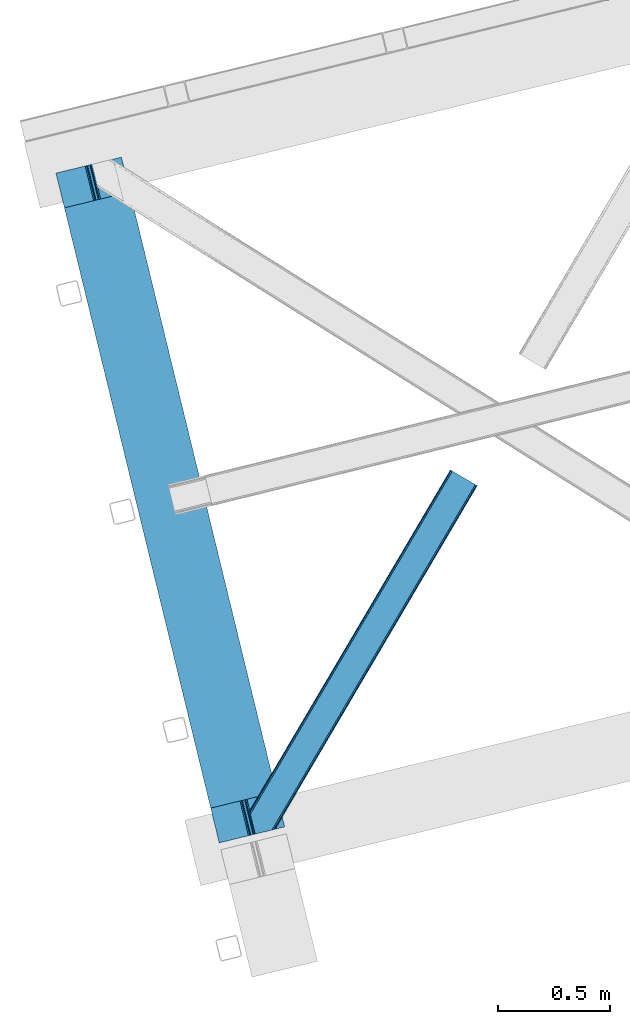
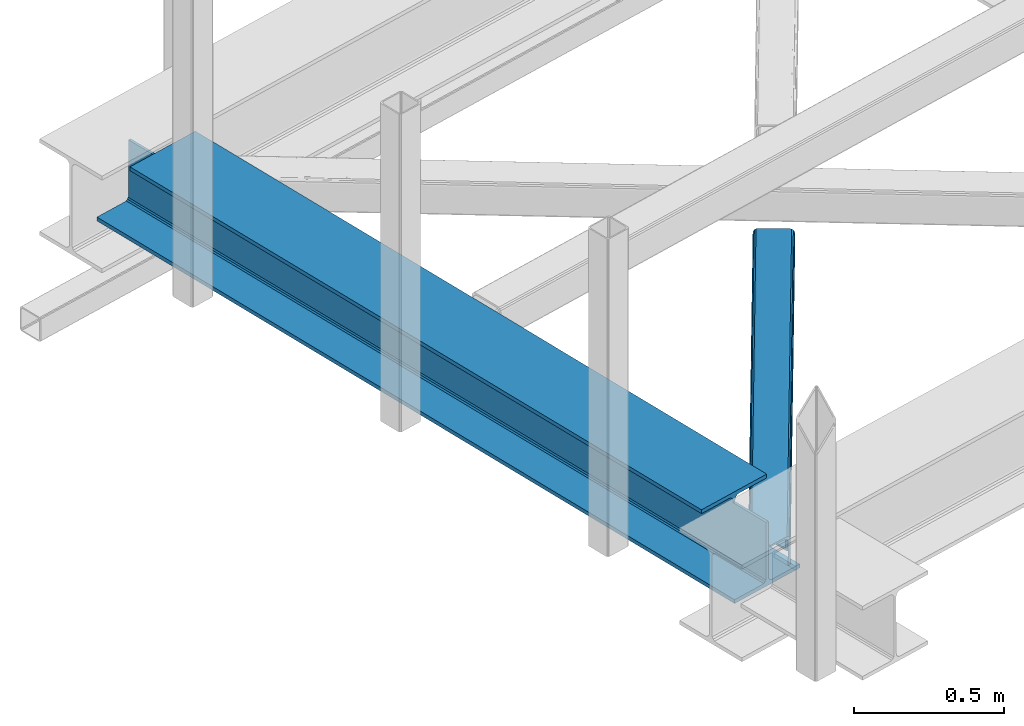
# One storey, part 17 of 67: 1 beam, 1 member.
"""IFC4 building model written with IfcOpenShell, lengths in millimetres."""

from ifc_helpers import new_model, entity, si_unit, converted_unit, derived_unit, direction, frame, origin, place, context, subcontext, project, spatial, triangles, polygons, material, type_object, element, save


model = new_model("IFC4")

# Units and contexts
model_context = context("Model", 3, precision=0.01, world=origin(), true_north=direction((6.12303176911189e-17, 1.0)))
plan_context = context("Plan", 3, precision=0.01, world=origin(), true_north=direction((6.12303176911189e-17, 1.0)))
body_context = subcontext(model_context, "Body", "Model", "MODEL_VIEW")
ifc_project = project(units=[si_unit("LENGTHUNIT", "METRE", prefix="MILLI"), si_unit("AREAUNIT", "SQUARE_METRE"), si_unit("VOLUMEUNIT", "CUBIC_METRE"), converted_unit("PLANEANGLEUNIT", "DEGREE", entity("IfcRatioMeasure", 0.0174532925199433), si_unit("PLANEANGLEUNIT", "RADIAN"), dimensions=[0, 0, 0, 0, 0, 0, 0]), si_unit("MASSUNIT", "GRAM", prefix="KILO"), derived_unit("MASSDENSITYUNIT", [(si_unit("MASSUNIT", "GRAM", prefix="KILO"), 1), (si_unit("LENGTHUNIT", "METRE"), -3)]), derived_unit("MOMENTOFINERTIAUNIT", [(si_unit("LENGTHUNIT", "METRE"), 4)]), si_unit("TIMEUNIT", "SECOND"), si_unit("FREQUENCYUNIT", "HERTZ"), si_unit("THERMODYNAMICTEMPERATUREUNIT", "DEGREE_CELSIUS"), derived_unit("THERMALTRANSMITTANCEUNIT", [(si_unit("MASSUNIT", "GRAM", prefix="KILO"), 1), (si_unit("THERMODYNAMICTEMPERATUREUNIT", "KELVIN"), -1), (si_unit("TIMEUNIT", "SECOND"), -3)]), derived_unit("VOLUMETRICFLOWRATEUNIT", [(si_unit("LENGTHUNIT", "METRE"), 3), (si_unit("TIMEUNIT", "SECOND"), -1)]), derived_unit("MASSFLOWRATEUNIT", [(si_unit("MASSUNIT", "GRAM", prefix="KILO"), 1), (si_unit("TIMEUNIT", "SECOND"), -1)]), derived_unit("ROTATIONALFREQUENCYUNIT", [(si_unit("TIMEUNIT", "SECOND"), -1)]), si_unit("ELECTRICCURRENTUNIT", "AMPERE"), si_unit("ELECTRICVOLTAGEUNIT", "VOLT"), si_unit("POWERUNIT", "WATT"), si_unit("FORCEUNIT", "NEWTON", prefix="KILO"), si_unit("ILLUMINANCEUNIT", "LUX"), si_unit("LUMINOUSFLUXUNIT", "LUMEN"), si_unit("LUMINOUSINTENSITYUNIT", "CANDELA"), derived_unit("USERDEFINED", [(si_unit("MASSUNIT", "GRAM", prefix="KILO"), -1), (si_unit("LENGTHUNIT", "METRE"), -2), (si_unit("TIMEUNIT", "SECOND"), 3), (si_unit("LUMINOUSFLUXUNIT", "LUMEN"), 1)]), derived_unit("LINEARVELOCITYUNIT", [(si_unit("LENGTHUNIT", "METRE"), 1), (si_unit("TIMEUNIT", "SECOND"), -1)]), si_unit("PRESSUREUNIT", "PASCAL"), derived_unit("USERDEFINED", [(si_unit("LENGTHUNIT", "METRE"), -2), (si_unit("MASSUNIT", "GRAM", prefix="KILO"), 1), (si_unit("TIMEUNIT", "SECOND"), -2)]), derived_unit("LINEARFORCEUNIT", [(si_unit("MASSUNIT", "GRAM", prefix="KILO"), 1), (si_unit("LENGTHUNIT", "METRE"), 1), (si_unit("TIMEUNIT", "SECOND"), -2), (si_unit("LENGTHUNIT", "METRE"), -1)]), derived_unit("PLANARFORCEUNIT", [(si_unit("MASSUNIT", "GRAM", prefix="KILO"), 1), (si_unit("LENGTHUNIT", "METRE"), 1), (si_unit("TIMEUNIT", "SECOND"), -2), (si_unit("LENGTHUNIT", "METRE"), -2)])], contexts=[model_context, plan_context])

# Site, building, storey
site_placement = place(None, origin())
site = spatial("IfcSite", under=ifc_project, at=site_placement, CompositionType="ELEMENT")
building_placement = place(site_placement, origin())
building = spatial("IfcBuilding", under=site, at=building_placement, CompositionType="ELEMENT")
storey_placement = place(building_placement, frame((0.0, 0.0, 19800.0)))
storey = spatial("IfcBuildingStorey", under=building, at=storey_placement, CompositionType="ELEMENT", Elevation=19800.0)

# Beam
ifc_material = material(Name="Metal painted (White)")
beam_type = type_object("IfcBeamType", PredefinedType="BEAM")
beam_placement = place(storey_placement, frame((-61151.8074958048, 2888.52916216723, 3808.0)))
element("IfcBeam", 1, at=beam_placement, inside=storey, type_object=beam_type, material=ifc_material, ObjectType="Steel Beam", PredefinedType="BEAM", context=body_context, shape_type="Tessellation", body=[
    polygons([(291.465617442446, 3052.25531830421, 15.5000000000051), (1018.16648378329, 71.0478278971005, 15.5000000000051), (1018.16648378329, 71.0478278971005, 0.0), (291.465617442446, 3052.25531830421, 0.0), (168.078506058482, 3022.17840449444, 15.5000000000051), (894.779372399338, 40.9709140873275, 15.5000000000051), (888.087028625375, 39.3395844888227, 16.8701684148028), (161.38616228452, 3020.54707489594, 16.8701684148028), (882.413533524751, 37.9566100336502, 20.7720779386478), (155.712667183895, 3019.16410044076, 20.7720779386478), (878.622625296176, 37.0325360459167, 26.6116982174338), (151.92175895532, 3018.24002645303, 26.6116982174338), (877.291435352788, 36.7080444135018, 33.500000000001), (150.590569011924, 3017.91553482062, 33.500000000001), (140.875048430514, 3015.54727389071, 33.500000000001), (140.875048430514, 3015.54727389071, 259.000000000006), (150.590569011924, 3017.91553482062, 259.000000000006), (8.66293703438714e-12, 2981.20749040711, 4.33146851719357e-12), (8.66293703438714e-12, 2981.20749040711, 15.5000000000051), (123.387111383964, 3011.28440421689, 15.5000000000051), (130.079455157926, 3012.91573381539, 16.8701684148028), (135.752950258551, 3014.29870827056, 20.7720779386478), (139.543858487117, 3015.2227822583, 26.6116982174338), (867.575914771369, 34.3397834835981, 259.000000000006), (867.575914771369, 34.3397834835981, 33.500000000001), (866.244724827964, 34.0152918511832, 26.6116982174338), (862.453816599389, 33.0912178634492, 20.7720779386478), (856.780321498782, 31.7082434082773, 16.8701684148028), (850.087977724819, 30.0769138097725, 15.5000000000051), (726.700866340855, -5.41433564649196e-13, 15.5000000000051), (726.700866340855, -5.41433564649196e-13, 4.33146851719357e-12), (877.291435352779, 36.7080444135018, 259.000000000006), (839.723099725414, 190.827961666228, 259.069792599954), (188.068298227656, 2864.16742161973, 259.000000000006), (188.291691329488, 2863.25097721476, 259.617303331129), (188.304080173113, 2863.20015298098, 266.500003008253), (839.577920935824, 191.42343960925, 266.500002998871), (839.578271056576, 191.422003304517, 260.000004007593), (830.098162489501, 188.087889491629, 259.00634317046), (829.874792453787, 189.004341089458, 259.617303331129), (829.862403610171, 189.055165323232, 266.500003008253), (178.588562847469, 2860.83187869496, 266.500002998871), (178.588212726726, 2860.8333149997, 260.000004007593), (178.443407068381, 2861.42736381349, 259.076120467494), (178.352777646237, 2861.79916068982, 259.000000000006), (840.909408805742, 191.746709053936, 273.388305639792), (844.699685394447, 192.673374225849, 279.227924098781), (850.372756341977, 194.058088689526, 283.129832400619), (857.06494802311, 195.690042220339, 284.500000377228), (980.451976710963, 225.76729527545, 284.500000138975), (980.450306904294, 225.774145344182, 299.999995328161), (688.984884807024, 154.72551608014, 299.999995890966), (688.986554613684, 154.718666011408, 284.500000701776), (812.373583301528, 184.795919066519, 284.500000463524), (819.066070197667, 186.426661533098, 283.129832461069), (824.739981846427, 187.807927177623, 279.227924137327), (828.531516633419, 188.72943082692, 273.388305663689), (177.257074977542, 2860.50860925028, 273.388305639792), (173.466798388846, 2859.58194407836, 279.227924098781), (167.793727441316, 2858.19722961469, 283.129832400619), (161.101535760182, 2856.56527608388, 284.500000377228), (37.7145070723384, 2826.48802302876, 284.500000138975), (37.7161768789901, 2826.48117296003, 299.999995328161), (329.181598976269, 2897.52980222408, 299.999995890962), (329.1799291696, 2897.53665229281, 284.500000701776), (205.792900481765, 2867.4593992377, 284.500000463524), (199.100413585626, 2865.82865677112, 283.129832461069), (193.426501936857, 2864.44739112659, 279.227924137327), (189.634967149874, 2863.52588747729, 273.388305663689)], [[[1, 2, 3, 4]], [[5, 6, 2, 1]], [[7, 6, 5, 8]], [[9, 7, 8, 10]], [[11, 9, 10, 12]], [[13, 11, 12, 14]], [[15, 16, 17, 14, 12, 10, 8, 5, 1, 4, 18, 19, 20, 21, 22, 23]], [[24, 25, 26, 27, 28, 29, 30, 31, 3, 2, 6, 7, 9, 11, 13, 32]], [[4, 3, 31, 18]], [[18, 31, 30, 19]], [[19, 30, 29, 20]], [[26, 25, 15, 23]], [[27, 26, 23, 22]], [[28, 27, 22, 21]], [[29, 28, 21, 20]], [[33, 32, 13, 14, 17, 34, 35, 36, 37, 38]], [[24, 39, 40, 41, 42, 43, 44, 16, 15, 25]], [[39, 24, 32, 33]], [[45, 34, 17, 16]], [[41, 40, 38, 37, 46, 47, 48, 49, 50, 51, 52, 53, 54, 55, 56, 57]], [[42, 58, 59, 60, 61, 62, 63, 64, 65, 66, 67, 68, 69, 36, 35, 43]], [[46, 37, 36, 69]], [[47, 46, 69, 68]], [[48, 47, 68, 67]], [[49, 48, 67, 66]], [[50, 49, 66, 65]], [[51, 50, 65, 64]], [[52, 51, 64, 63]], [[53, 52, 63, 62]], [[54, 53, 62, 61]], [[55, 54, 61, 60]], [[56, 55, 60, 59]], [[57, 56, 59, 58]], [[41, 57, 58, 42]]], closed=False),
])

# Member
member_type = type_object("IfcMemberType", PredefinedType="BRACE")
member_placement = place(storey_placement, frame((-60290.0501953125, 2927.61955718994, 3823.99987792968)))
element("IfcMember", 2, at=member_placement, inside=storey, type_object=member_type, ObjectType="Steel Horizontal Brace", PredefinedType="BRACE", context=body_context, shape_type="Tessellation", body=[
    triangles([(154.446386718751, 124.708666992187, 0.0), (118.769494628912, 271.071535491943, 0.0), (998.971582031256, 1559.19843292236, 0.0), (908.488732910162, 1612.46872787476, 0.0), (1004.74332275391, 1555.80096588135, 1.33247680664135), (156.720666503912, 115.373480987549, 1.33247680664135), (1009.63139648438, 1552.92061843872, 5.12526855468968), (158.650781250006, 107.459719848633, 5.12526855468968), (1012.90096435547, 1550.99602661133, 10.8039916992202), (159.939074707036, 102.171670532226, 10.8039916992202), (1014.04973144532, 1550.32019577026, 17.5012573242202), (160.39486083985, 100.314807128906, 17.5012573242202), (902.716992187503, 1615.86619491577, 1.33247680664135), (116.495214843751, 280.40643081665, 1.33247680664135), (114.574401855469, 288.275717926025, 5.1694519042976), (897.824267578129, 1618.74683303833, 5.12526855468968), (114.495336914064, 288.596628570557, 5.32758178711083), (894.554699707034, 1620.67142486572, 10.8039916992202), (109.625866699222, 287.408910369873, 10.8039916992202), (893.405932617192, 1621.34696502686, 17.5012573242202), (107.821325683595, 286.969111633301, 17.5012573242202), (113.523303222661, 288.35972442627, 18.5197998046897), (114.495336914064, 288.596628570557, 17.5198608398459), (114.420922851568, 288.578606414795, 17.9035583496116), (114.211633300787, 288.527156066894, 18.2267944335945), (113.895373535161, 288.450416564941, 18.4453857421868), (107.821325683595, 286.969111633301, 18.5197998046897), (115.695263671878, 283.683556365967, 17.5198608398459), (115.625500488284, 283.800409698486, 17.8035644531265), (115.565039062501, 283.740238952636, 17.8570495605491), (115.323193359378, 283.495486450195, 18.0779663085959), (115.067395019534, 283.239106750488, 18.3081848144539), (114.830200195313, 283.003074645996, 18.5197998046897), (0.0, 103.824476623535, 18.5197998046897), (2.73471679687646, 92.5987083435057, 18.5197998046897), (893.405932617192, 1621.34696502686, 122.499499511719), (0.0, 103.824476623535, 122.499499511719), (908.488732910162, 1612.46872787476, 140.00075683594), (902.716992187503, 1615.86619491577, 138.668280029298), (3.66954345703562, 88.7658027648927, 138.668280029298), (5.94382324218896, 79.430616760254, 140.00075683594), (897.824267578129, 1618.74683303833, 134.87548828125), (1.73942871094187, 96.6798545837401, 134.87548828125), (894.554699707034, 1620.67142486572, 129.196765136719), (0.451135253912071, 101.967613220215, 129.196765136719), (899.438122558597, 1617.795728302, 24.5008300781265), (2.37659912109666, 94.0669326782227, 24.5008300781265), (900.586889648439, 1617.11989746094, 17.8035644531265), (903.856457519534, 1615.19530563355, 12.1248413085959), (914.516271972658, 1608.9174911499, 6.99957275390625), (908.749182128908, 1612.31495819092, 8.3320495605476), (118.871813964848, 270.648886871338, 8.3320495605476), (121.146093750001, 261.313991546631, 6.99957275390625), (116.941699218754, 278.562938690186, 12.1248413085959), (152.069787597662, 134.4662109375, 6.99957275390625), (992.939392089844, 1562.74996032715, 6.99957275390625), (156.274182128909, 117.217263793945, 12.1248413085959), (154.344067382815, 125.131024932861, 8.3320495605476), (157.520617675786, 112.096646118164, 17.5198608398459), (160.39486083985, 100.314807128906, 17.5198608398459), (899.438122558597, 1617.795728302, 115.499926757813), (2.37659912109666, 94.0669326782227, 115.499926757813), (900.586889648439, 1617.11989746094, 122.197192382813), (2.82773437500146, 92.2100692749023, 122.197192382813), (903.856457519534, 1615.19530563355, 127.873590087893), (4.12067871094041, 86.9223106384275, 127.873590087893), (908.749182128908, 1612.31495819092, 131.668707275392), (6.046142578125, 79.0082588195801, 131.668707275392), (914.516271972658, 1608.9174911499, 133.001184082033), (8.3250732421875, 69.6733634948728, 133.001184082033), (25.3054321289092, 0.0, 133.001184082033), (25.3054321289092, 0.0, 140.00075683594), (90.3619262695356, 15.8580436706543, 140.00075683594), (998.971582031256, 1559.19843292236, 140.00075683594), (1014.04973144532, 1550.32019577026, 122.499499511719), (1012.90096435547, 1550.99602661133, 129.196765136719), (114.0721069336, 21.6376327514649, 122.499499511719), (112.267565917973, 21.1975433349608, 129.196765136719), (1009.63139648438, 1552.92061843872, 134.87548828125), (107.128344726567, 19.9447128295897, 134.87548828125), (1004.74332275391, 1555.80096588135, 138.668280029298), (99.435791015625, 18.0698272705076, 138.668280029298), (159.664672851563, 99.0785453796384, 18.5197998046897), (114.0721069336, 21.6376327514649, 18.5197998046897), (103.161145019534, 18.9779113769532, 18.5197998046897), (156.929956054693, 110.304313659668, 18.5197998046897), (1008.01754150391, 1553.87143249512, 24.5008300781265), (1006.86877441406, 1554.54726333618, 17.8035644531265), (157.222961425781, 111.200479888916, 18.0198303222678), (1003.59920654297, 1556.47185516357, 12.1248413085959), (998.706481933594, 1559.3522026062, 8.3320495605476), (104.588964843751, 19.325855255127, 24.5008300781265), (1003.59920654297, 1556.47185516357, 127.873590087893), (1008.01754150391, 1553.87143249512, 115.499926757813), (1006.86877441406, 1554.54726333618, 122.197192382813), (992.939392089844, 1562.74996032715, 133.001184082033), (998.706481933594, 1559.3522026062, 131.668707275392), (102.784423828125, 18.8857658386228, 122.197192382813), (80.8787841796875, 13.5462661743163, 133.001184082033), (89.9526489257842, 15.7577590942383, 131.668707275392), (97.6452026367188, 17.6329353332517, 127.873590087893), (104.588964843751, 19.325855255127, 115.499926757813)], [[1, 2, 3], [4, 3, 2], [3, 5, 1], [6, 1, 5], [5, 7, 6], [8, 6, 7], [7, 9, 8], [10, 8, 9], [9, 11, 10], [12, 10, 11], [13, 14, 15], [16, 15, 17], [17, 18, 16], [17, 19, 18], [20, 18, 19], [19, 21, 20], [15, 16, 13], [13, 4, 14], [2, 14, 4], [22, 23, 24], [22, 25, 26], [27, 21, 22], [24, 25, 22], [23, 22, 21], [21, 19, 23], [17, 23, 19], [23, 28, 29], [29, 24, 23], [25, 24, 30], [26, 25, 31], [22, 26, 32], [32, 33, 22], [31, 32, 26], [30, 31, 25], [29, 30, 24], [34, 33, 35], [33, 34, 27], [22, 33, 27], [27, 20, 21], [36, 27, 37], [27, 36, 20], [27, 34, 37], [38, 39, 40], [40, 41, 38], [39, 42, 43], [43, 40, 39], [42, 44, 45], [45, 43, 42], [44, 36, 37], [37, 45, 44], [46, 47, 33], [33, 48, 46], [33, 31, 48], [47, 35, 33], [49, 48, 28], [50, 51, 52], [52, 53, 50], [51, 49, 54], [54, 52, 51], [28, 54, 49], [53, 55, 56], [56, 50, 53], [55, 2, 1], [54, 17, 14], [52, 14, 2], [52, 2, 53], [55, 53, 2], [17, 28, 23], [54, 28, 17], [52, 54, 14], [57, 58, 6], [58, 1, 6], [1, 58, 55], [8, 57, 6], [8, 59, 57], [10, 59, 8], [10, 60, 59], [46, 61, 47], [62, 47, 61], [61, 63, 62], [64, 62, 63], [63, 65, 64], [66, 64, 65], [65, 67, 66], [68, 66, 67], [67, 69, 68], [70, 68, 69], [66, 43, 64], [71, 72, 70], [72, 41, 70], [40, 68, 41], [66, 68, 40], [68, 70, 41], [66, 40, 43], [37, 34, 62], [45, 64, 43], [62, 64, 37], [64, 45, 37], [34, 47, 62], [34, 35, 47], [41, 73, 74], [73, 41, 72], [74, 38, 41], [75, 76, 77], [78, 77, 76], [76, 79, 78], [80, 78, 79], [79, 81, 80], [82, 80, 81], [81, 74, 82], [73, 82, 74], [60, 75, 77], [60, 11, 75], [77, 83, 60], [77, 84, 83], [84, 85, 83], [86, 83, 85], [87, 88, 59], [89, 86, 87], [88, 90, 57], [57, 59, 88], [90, 91, 58], [58, 57, 90], [91, 56, 55], [55, 58, 91], [87, 86, 92], [85, 92, 86], [9, 90, 88], [87, 75, 11], [9, 88, 11], [9, 7, 90], [88, 87, 11], [90, 7, 5], [56, 3, 4], [3, 91, 5], [91, 3, 56], [91, 90, 5], [76, 93, 79], [94, 75, 87], [75, 95, 76], [95, 75, 94], [76, 95, 93], [74, 96, 38], [81, 79, 93], [93, 97, 81], [97, 96, 74], [74, 81, 97], [49, 13, 16], [4, 50, 56], [4, 51, 50], [51, 4, 13], [49, 51, 13], [46, 20, 36], [18, 48, 49], [16, 18, 49], [48, 18, 20], [46, 48, 20], [39, 65, 42], [38, 96, 69], [69, 67, 38], [67, 65, 39], [39, 38, 67], [44, 42, 65], [36, 61, 46], [63, 36, 44], [36, 63, 61], [63, 44, 65], [98, 78, 80], [99, 73, 72], [72, 71, 99], [99, 100, 73], [100, 82, 73], [101, 82, 100], [80, 82, 101], [98, 77, 78], [102, 77, 98], [80, 101, 98], [84, 92, 85], [102, 84, 77], [92, 84, 102], [99, 70, 96], [99, 71, 70], [69, 96, 70], [96, 97, 100], [100, 99, 96], [97, 93, 101], [101, 100, 97], [93, 95, 98], [98, 101, 93], [95, 94, 102], [102, 98, 95], [94, 87, 102], [92, 102, 87]]),
])

save(model, "model.ifc")
